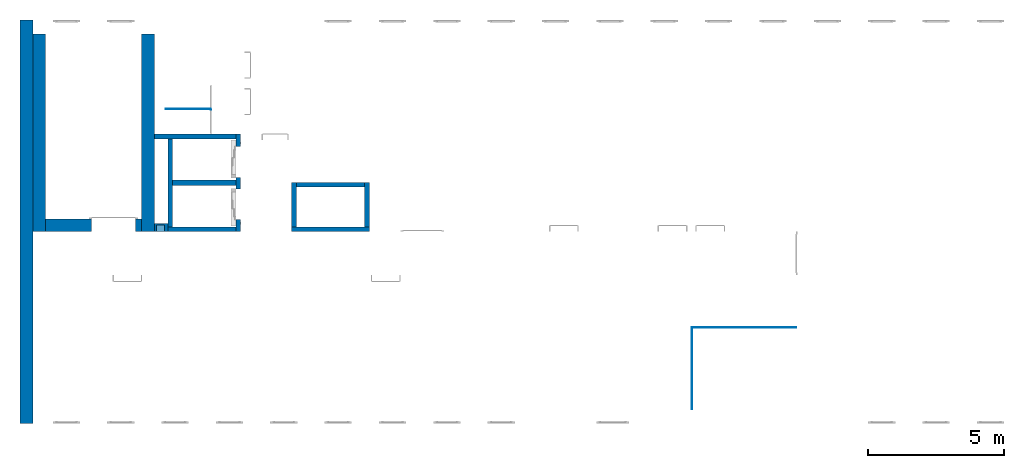
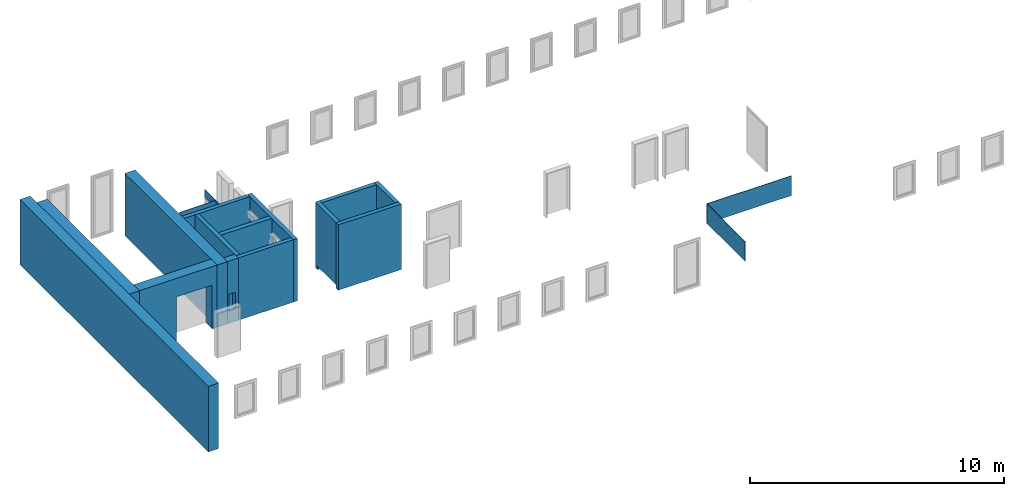
# One storey, part 1 of 5: 18 walls, 6 openings.
"""IFC4 building model written with IfcOpenShell, lengths in metres."""

from ifc_helpers import new_model, entity, si_unit, converted_unit, derived_unit, direction, frame, origin_with_axes, place, context, subcontext, project, spatial, polygons, material, type_object, element, save


model = new_model("IFC4")

# Units and contexts
model_context = context("Model", 3, precision=1e-05, world=origin_with_axes(), true_north=direction((0.0, 1.0)))
body_context = subcontext(model_context, "Body", "Model", "MODEL_VIEW")
ifc_project = project(units=[si_unit("LENGTHUNIT", "METRE"), si_unit("AREAUNIT", "SQUARE_METRE"), si_unit("VOLUMEUNIT", "CUBIC_METRE"), converted_unit("PLANEANGLEUNIT", "DEGREE", entity("IfcPlaneAngleMeasure", 0.0174532925199433), si_unit("PLANEANGLEUNIT", "RADIAN"), dimensions=[0, 0, 0, 0, 0, 0, 0]), converted_unit("TIMEUNIT", "Year", entity("IfcTimeMeasure", 31557600.0), si_unit("TIMEUNIT", "SECOND"), dimensions=[0, 0, 1, 0, 0, 0, 0]), si_unit("MASSUNIT", "GRAM", prefix="KILO"), si_unit("THERMODYNAMICTEMPERATUREUNIT", "DEGREE_CELSIUS"), si_unit("LUMINOUSINTENSITYUNIT", "LUMEN"), si_unit("ENERGYUNIT", "JOULE", prefix="MEGA"), derived_unit("THERMALCONDUCTANCEUNIT", [(si_unit("POWERUNIT", "WATT"), 1), (si_unit("LENGTHUNIT", "METRE"), -1), (si_unit("THERMODYNAMICTEMPERATUREUNIT", "KELVIN"), -1)]), derived_unit("SPECIFICHEATCAPACITYUNIT", [(si_unit("ENERGYUNIT", "JOULE"), 1), (si_unit("MASSUNIT", "GRAM", prefix="KILO"), -1), (si_unit("THERMODYNAMICTEMPERATUREUNIT", "KELVIN"), -1)]), derived_unit("MASSDENSITYUNIT", [(si_unit("MASSUNIT", "GRAM", prefix="KILO"), 1), (si_unit("VOLUMEUNIT", "CUBIC_METRE"), -1)])], contexts=[model_context])

# Site, building, storey
site_placement = place(None, origin_with_axes())
site = spatial("IfcSite", under=ifc_project, at=site_placement, CompositionType="ELEMENT")
building_placement = place(None, origin_with_axes())
building = spatial("IfcBuilding", under=site, at=building_placement, CompositionType="ELEMENT")
storey_placement = place(None, frame((0.0, 0.0, 4.5), z_axis=(0.0, 0.0, 1.0), x_axis=(1.0, 0.0, 0.0)))
storey = spatial("IfcBuildingStorey", under=building, at=storey_placement, Name="1 OG", CompositionType="ELEMENT", Elevation=4.5)

# Walls
ifc_material_1 = material(Name="Stahlbeton")
wall_type_1 = type_object("IfcWallType", Name="Stahlbeton 180", PredefinedType="NOTDEFINED")
wall_1_placement = place(None, frame((36.373, 7.05499994546756, 4.5), z_axis=(0.0, 0.0, 1.0), x_axis=(0.0, 1.0, 0.0)))
element("IfcWall", 1, at=wall_1_placement, inside=storey, type_object=wall_type_1, material=ifc_material_1, Name="Wand-001", PredefinedType="NOTDEFINED", context=body_context, shape_type="Tessellation", body=[
    polygons([(1.818, 0.18, 0.0), (1.818, 0.0, 0.0), (0.18, 0.0, 0.0), (0.18, 0.18, 0.0), (1.818, 0.18, 3.0), (1.818, 0.0, 3.0), (0.18, 0.0, 3.0), (0.18, 0.18, 3.0)], [[[1, 2, 3, 4]], [[2, 1, 5, 6]], [[2, 6, 7, 3]], [[8, 4, 3, 7]], [[5, 1, 4, 8]], [[6, 5, 8, 7]]], closed=True),
])
wall_2_placement = place(None, frame((28.958, 7.05499994546755, 4.5), z_axis=(0.0, 0.0, 1.0), x_axis=(1.0, 0.0, 0.0)))
element("IfcWall", 2, at=wall_2_placement, inside=storey, type_object=wall_type_1, material=ifc_material_1, Name="Wand-001", PredefinedType="NOTDEFINED", context=body_context, shape_type="Tessellation", body=[
    polygons([(2.5, 0.180000000000001, 0.0), (2.5, 0.0, 0.0), (0.0, 0.0, 0.0), (0.0, 0.18, 0.0), (2.5, 0.180000000000001, 3.0), (2.5, 0.0, 3.0), (0.0, 0.0, 3.0), (0.0, 0.180000000000001, 3.0)], [[[1, 2, 3, 4]], [[2, 1, 5, 6]], [[2, 6, 7, 3]], [[8, 4, 3, 7]], [[5, 1, 4, 8]], [[6, 5, 8, 7]]], closed=True),
])
wall_3_placement = place(None, frame((36.373, 8.87299994546756, 4.35), z_axis=(0.0, 0.0, 1.0), x_axis=(-1.0, 0.0, 0.0)))
element("IfcWall", 3, at=wall_3_placement, inside=storey, type_object=wall_type_1, material=ifc_material_1, Name="Wand-001", PredefinedType="NOTDEFINED", context=body_context, shape_type="Tessellation", body=[
    polygons([(2.688, 0.0, 3.15), (0.18, 0.0, 3.15), (0.18, 0.0, 0.15), (0.0, 0.0, 0.15), (0.0, 0.0, 0.0), (2.868, 0.0, 0.0), (2.868, 0.0, 0.15), (2.688, 0.0, 0.15), (2.688, 0.18, 3.15), (0.18, 0.18, 3.15), (0.18, 0.18, 0.15), (0.0, 0.18, 0.15), (0.0, 0.18, 0.0), (2.868, 0.18, 0.0), (2.868, 0.18, 0.15), (2.688, 0.18, 0.15)], [[[1, 2, 3, 4, 5, 6, 7, 8]], [[9, 10, 2, 1]], [[11, 3, 2, 10]], [[11, 12, 4, 3]], [[5, 4, 12, 13]], [[5, 13, 14, 6]], [[14, 15, 7, 6]], [[16, 8, 7, 15]], [[16, 9, 1, 8]], [[12, 11, 10, 9, 16, 15, 14, 13]]], closed=True),
])
wall_4_placement = place(None, frame((29.138, 7.05499994546755, 4.5), z_axis=(0.0, 0.0, 1.0), x_axis=(0.0, 1.0, 0.0)))
element("IfcWall", 4, at=wall_4_placement, inside=storey, type_object=wall_type_1, material=ifc_material_1, Name="Wand-003", PredefinedType="NOTDEFINED", context=body_context, shape_type="Tessellation", body=[
    polygons([(3.42, 0.18, 0.0), (3.42, 0.0, 0.0), (0.18, 0.0, 0.0), (0.18, 0.18, 0.0), (3.42, 0.18, 3.0), (3.42, 0.0, 3.0), (0.18, 0.0, 3.0), (0.18, 0.18, 3.0)], [[[1, 2, 3, 4]], [[2, 1, 5, 6]], [[2, 6, 7, 3]], [[8, 4, 3, 7]], [[5, 1, 4, 8]], [[6, 5, 8, 7]]], closed=True),
])
wall_5_placement = place(None, frame((31.638, 10.6549999454676, 4.5), z_axis=(0.0, 0.0, 1.0), x_axis=(-1.0, 0.0, 0.0)))
element("IfcWall", 5, at=wall_5_placement, inside=storey, type_object=wall_type_1, material=ifc_material_1, Name="Wand-003", PredefinedType="NOTDEFINED", context=body_context, shape_type="Tessellation", body=[
    polygons([(3.18, 0.18, 0.0), (3.18, 0.0, 0.0), (0.18, 0.0, 0.0), (0.18, 0.18, 0.0), (3.18, 0.18, 3.0), (3.18, 0.0, 3.0), (0.18, 0.0, 3.0), (0.18, 0.18, 3.0)], [[[1, 2, 3, 4]], [[2, 1, 5, 6]], [[2, 6, 7, 3]], [[8, 4, 3, 7]], [[5, 1, 4, 8]], [[6, 5, 8, 7]]], closed=True),
])
wall_6_placement = place(None, frame((33.505, 7.05499994546756, 4.35), z_axis=(0.0, 0.0, 1.0), x_axis=(1.0, 0.0, 0.0)))
element("IfcWall", 6, at=wall_6_placement, inside=storey, type_object=wall_type_1, material=ifc_material_1, Name="Wand-001", PredefinedType="NOTDEFINED", context=body_context, shape_type="Tessellation", body=[
    polygons([(2.868, 0.0, 3.15), (2.868, 0.0, 0.15), (2.868, 0.18, 0.15), (2.868, 0.180000000000001, 3.15), (0.0, 0.0, 0.0), (2.868, 0.0, 0.0), (0.0, 0.0, 3.15), (0.0, 0.0, 0.15), (2.868, 0.18, 0.0), (0.0, 0.18, 0.0), (0.0, 0.18, 0.15), (0.0, 0.180000000000001, 3.15)], [[[1, 2, 3, 4]], [[5, 6, 2, 1, 7, 8]], [[6, 9, 3, 2]], [[4, 3, 9, 10, 11, 12]], [[7, 1, 4, 12]], [[10, 9, 6, 5]], [[12, 11, 8, 7]], [[5, 8, 11, 10]]], closed=True),
])
wall_7_placement = place(None, frame((33.505, 7.05499994546756, 4.5), z_axis=(0.0, 0.0, 1.0), x_axis=(0.0, 1.0, 0.0)))
element("IfcWall", 7, at=wall_7_placement, inside=storey, type_object=wall_type_1, material=ifc_material_1, Name="Wand-001", PredefinedType="NOTDEFINED", context=body_context, shape_type="Tessellation", body=[
    polygons([(1.818, -0.18, 3.0), (1.818, 0.0, 3.0), (0.18, 0.0, 3.0), (0.18, -0.18, 3.0), (1.818, -0.18, 0.0), (1.818, 0.0, 0.0), (0.18, 0.0, 0.0), (0.18, -0.18, 0.0)], [[[1, 2, 3, 4]], [[2, 1, 5, 6]], [[2, 6, 7, 3]], [[8, 4, 3, 7]], [[5, 1, 4, 8]], [[6, 5, 8, 7]]], closed=True),
])

# Wall, openings
wall_8_placement = place(None, frame((31.638, 7.05499994546755, 4.5), z_axis=(0.0, 0.0, 1.0), x_axis=(0.0, 1.0, 0.0)))
wall_8 = element("IfcWall", 8, at=wall_8_placement, inside=storey, type_object=wall_type_1, material=ifc_material_1, Name="Wand-002", PredefinedType="NOTDEFINED", context=body_context, shape_type="Tessellation", body=[
    polygons([(2.0, 0.0, 0.0), (2.0, 0.0, 2.25), (3.13, 0.0, 2.25), (3.13, 0.0, 0.0), (3.6, 0.0, 0.0), (3.6, 0.0, 3.0), (0.0, 0.0, 3.0), (0.0, 0.0, 0.0), (0.450000000000002, 0.0, 0.0), (0.450000000000002, 0.0, 2.25), (1.58, 0.0, 2.25), (1.58, 0.0, 0.0), (2.0, 0.179999999999996, 0.0), (2.0, 0.179999999999996, 2.25), (3.13, 0.179999999999996, 2.25), (3.13, 0.179999999999996, 0.0), (3.6, 0.179999999999996, 0.0), (3.6, 0.179999999999996, 3.0), (0.0, 0.18, 3.0), (0.0, 0.18, 0.0), (0.450000000000002, 0.18, 0.0), (0.450000000000002, 0.18, 2.25), (1.58, 0.18, 2.25), (1.58, 0.18, 0.0)], [[[1, 2, 3, 4, 5, 6, 7, 8, 9, 10, 11, 12]], [[2, 1, 13, 14]], [[3, 2, 14, 15]], [[4, 3, 15, 16]], [[4, 16, 17, 5]], [[18, 6, 5, 17]], [[19, 7, 6, 18]], [[8, 7, 19, 20]], [[9, 8, 20, 21]], [[9, 21, 22, 10]], [[10, 22, 23, 11]], [[11, 23, 24, 12]], [[13, 1, 12, 24]], [[14, 13, 24, 23, 22, 21, 20, 19, 18, 17, 16, 15]]], closed=True),
])
opening_1_placement = place(None, frame((31.638, 8.06999994546756, 4.5), z_axis=(0.0, 0.0, 1.0), x_axis=(0.0, 1.0, 0.0)))
element("IfcOpeningElement", 9, at=opening_1_placement, cuts=wall_8, context=body_context, identifier="Reference", shape_type="Tessellation", body=[
    polygons([(-0.565, -0.00100000000000122, 2.25), (-0.565, -0.00100000000000122, 0.0), (0.565, -0.00100000000000122, 0.0), (0.565, -0.00100000000000122, 2.25), (-0.565, 0.181000000000004, 2.25), (-0.565, 0.181000000000004, 0.0), (0.565000000000001, 0.181000000000004, 0.0), (0.565000000000001, 0.181000000000004, 2.25)], [[[1, 2, 3, 4]], [[5, 6, 2, 1]], [[6, 7, 3, 2]], [[7, 8, 4, 3]], [[8, 5, 1, 4]], [[7, 6, 5, 8]]], closed=True),
])
opening_2_placement = place(wall_8_placement, frame((2.565, 0.0, 0.0), z_axis=(0.0, 0.0, 1.0), x_axis=(1.0, 0.0, 0.0)))
element("IfcOpeningElement", 10, at=opening_2_placement, cuts=wall_8, context=body_context, identifier="Reference", shape_type="Tessellation", body=[
    polygons([(-0.565, -0.00100000000000478, 2.25), (-0.565, -0.00100000000000478, 0.0), (0.565, -0.00100000000000478, 0.0), (0.565, -0.00100000000000478, 2.25), (-0.564999999999998, 0.181000000000001, 2.25), (-0.564999999999998, 0.181000000000001, 0.0), (0.565000000000001, 0.181000000000001, 0.0), (0.565000000000001, 0.181000000000001, 2.25)], [[[1, 2, 3, 4]], [[5, 6, 2, 1]], [[6, 7, 3, 2]], [[7, 8, 4, 3]], [[8, 5, 1, 4]], [[7, 6, 5, 8]]], closed=True),
])

# Walls
wall_type_2 = type_object("IfcWallType", Name="Stahlbeton 470", PredefinedType="NOTDEFINED")
wall_9_placement = place(None, frame((27.988, 14.3259998818788, 4.5), z_axis=(0.0, 0.0, 1.0), x_axis=(0.0, -1.0, 0.0)))
element("IfcWall", 11, at=wall_9_placement, inside=storey, type_object=wall_type_2, material=ifc_material_1, Name="Wand-001", PredefinedType="NOTDEFINED", context=body_context, shape_type="Tessellation", body=[
    polygons([(7.27099993641123, 0.469999999999999, 0.0), (7.27099993641123, 0.0, 0.0), (0.0, 0.0, 0.0), (0.0, 0.469999999999999, 0.0), (7.27099993641123, 0.469999999999999, 3.0), (7.27099993641123, 0.0, 3.0), (0.0, 0.0, 3.0), (0.0, 0.469999999999999, 3.0)], [[[1, 2, 3, 4]], [[2, 1, 5, 6]], [[2, 6, 7, 3]], [[8, 4, 3, 7]], [[5, 1, 4, 8]], [[6, 5, 8, 7]]], closed=True),
])
wall_10_placement = place(None, frame((23.988, 14.8459998818788, 4.35), z_axis=(0.0, 0.0, 1.0), x_axis=(0.0, -1.0, 0.0)))
element("IfcWall", 12, at=wall_10_placement, inside=storey, type_object=wall_type_2, material=ifc_material_1, Name="Wand-001", PredefinedType="NOTDEFINED", context=body_context, shape_type="Tessellation", body=[
    polygons([(0.0, 0.0, 0.0), (0.0, 0.0, 3.15), (14.8459998818788, 0.0, 3.15), (14.8459998818788, 0.0, 0.0), (0.362999951604566, 0.0, 3.0), (0.362999951604566, 0.0, 2.63), (7.79099993641123, 0.0, 2.63), (14.4829998291425, 0.0, 2.63), (14.4829998291425, 0.0, 3.0), (7.79099993641123, 0.0, 3.0), (0.0, -0.469999999999999, 0.0), (0.0, -0.469999999999999, 3.15), (14.8459998818788, -0.469999999999999, 3.15), (14.8459998818788, -0.469999999999999, 0.0), (0.362999951604566, -0.100000000000008, 2.63), (0.362999951604566, -0.100000000000008, 3.0), (14.4829998289544, -0.100000000000008, 2.63), (14.4829998289544, -0.100000000000008, 3.0)], [[[1, 2, 3, 4], [5, 6, 7, 8, 9, 10]], [[1, 11, 12, 2]], [[2, 12, 13, 3]], [[4, 3, 13, 14]], [[11, 1, 4, 14]], [[15, 6, 5, 16]], [[8, 7, 6, 15, 17]], [[18, 9, 8, 17]], [[18, 16, 5, 10, 9]], [[12, 11, 14, 13]], [[17, 15, 16, 18]]], closed=True),
])
wall_11_placement = place(None, frame((24.458, 14.3318657372406, 4.5), z_axis=(0.0, 0.0, 1.0), x_axis=(0.0, -1.0, 0.0)))
element("IfcWall", 13, at=wall_11_placement, inside=storey, type_object=wall_type_2, material=ifc_material_1, Name="Wand-001", PredefinedType="NOTDEFINED", context=body_context, shape_type="Tessellation", body=[
    polygons([(7.27686579177299, -0.470000000000002, 3.0), (7.27686579177299, 0.0, 3.0), (0.0, 0.0, 3.0), (0.0, -0.469999999999999, 3.0), (7.27686579177299, -0.470000000000002, 0.0), (7.27686579177299, 0.0, 0.0), (0.0, 0.0, 0.0), (0.0, -0.469999999999999, 0.0)], [[[1, 2, 3, 4]], [[2, 1, 5, 6]], [[2, 6, 7, 3]], [[8, 4, 3, 7]], [[5, 1, 4, 8]], [[6, 5, 8, 7]]], closed=True),
])

# Wall, opening
wall_12_placement = place(None, frame((24.458, 7.52499994546755, 4.5), z_axis=(0.0, 0.0, 1.0), x_axis=(1.0, 0.0, 0.0)))
wall_12 = element("IfcWall", 14, at=wall_12_placement, inside=storey, type_object=wall_type_2, material=ifc_material_1, Name="Wand-001", PredefinedType="NOTDEFINED", context=body_context, shape_type="Tessellation", body=[
    polygons([(1.69000000000001, 0.0, 2.11), (1.69000000000001, 0.0, 0.0), (0.0, 0.0, 0.0), (0.0, 0.0, 3.0), (3.53, 0.0, 3.0), (3.53, 0.0, 0.0), (3.31, 0.0, 0.0), (3.31, 0.0, 2.11), (1.69000000000001, -0.47, 2.11), (1.69000000000001, -0.47, 0.0), (0.0, -0.47, 0.0), (0.0, -0.47, 3.0), (3.53, -0.47, 3.0), (3.53, -0.47, 0.0), (3.31, -0.47, 0.0), (3.31, -0.47, 2.11)], [[[1, 2, 3, 4, 5, 6, 7, 8]], [[2, 1, 9, 10]], [[2, 10, 11, 3]], [[12, 4, 3, 11]], [[5, 4, 12, 13]], [[13, 14, 6, 5]], [[15, 7, 6, 14]], [[8, 7, 15, 16]], [[1, 8, 16, 9]], [[16, 15, 14, 13, 12, 11, 10, 9]]], closed=True),
])
opening_3_placement = place(wall_12_placement, frame((2.5, 0.0, 0.0), z_axis=(0.0, 0.0, 1.0), x_axis=(1.0, 0.0, 0.0)))
element("IfcOpeningElement", 15, at=opening_3_placement, cuts=wall_12, context=body_context, identifier="Reference", shape_type="Tessellation", body=[
    polygons([(-0.809999999999999, -0.471, 2.11), (-0.809999999999999, -0.471, 0.0), (0.809999999999999, -0.471, 0.0), (0.809999999999999, -0.471, 2.11), (-0.809999999999999, 0.00100000000000033, 2.11), (-0.809999999999999, 0.00100000000000033, 0.0), (0.809999999999999, 0.00100000000000033, 0.0), (0.809999999999999, 0.00100000000000033, 2.11)], [[[1, 2, 3, 4]], [[5, 6, 2, 1]], [[6, 7, 3, 2]], [[7, 8, 4, 3]], [[8, 5, 1, 4]], [[7, 6, 5, 8]]], closed=True),
])

# Wall
wall_type_3 = type_object("IfcWallType", Name="Stahlbeton 200", PredefinedType="NOTDEFINED")
wall_13_placement = place(None, frame((29.138, 8.85499994546755, 4.5), z_axis=(0.0, 0.0, 1.0), x_axis=(1.0, 0.0, 0.0)))
element("IfcWall", 16, at=wall_13_placement, inside=storey, type_object=wall_type_3, material=ifc_material_1, Name="Wand-001", PredefinedType="NOTDEFINED", context=body_context, shape_type="Tessellation", body=[
    polygons([(2.32, 0.0999999999999996, 0.0), (2.32, -0.0999999999999996, 0.0), (0.0, -0.0999999999999996, 0.0), (0.0, 0.0999999999999996, 0.0), (2.32, 0.0999999999999996, 3.0), (2.32, -0.0999999999999996, 3.0), (0.0, -0.0999999999999996, 3.0), (0.0, 0.0999999999999996, 3.0)], [[[1, 2, 3, 4]], [[2, 1, 5, 6]], [[2, 6, 7, 3]], [[8, 4, 3, 7]], [[5, 1, 4, 8]], [[6, 5, 8, 7]]], closed=True),
])

# Wall, opening
wall_type_4 = type_object("IfcWallType", Name="Stahlbeton 300", PredefinedType="NOTDEFINED")
wall_14_placement = place(None, frame((28.458, 7.05499994546755, 4.5), z_axis=(0.0, 0.0, 1.0), x_axis=(1.0, 0.0, 0.0)))
wall_14 = element("IfcWall", 17, at=wall_14_placement, inside=storey, type_object=wall_type_4, material=ifc_material_1, Name="Wand-001", PredefinedType="NOTDEFINED", context=body_context, shape_type="Tessellation", body=[
    polygons([(0.0, 0.0, 3.0), (0.0, 0.0, 0.0), (0.5, 0.0, 0.0), (0.5, 0.0, 3.0), (0.375425898351669, 0.0, 0.6), (0.0754258983516713, 0.0, 0.6), (0.0754258983516713, 0.0, 1.4), (0.375425898351669, 0.0, 1.4), (0.0, 0.3, 3.0), (0.0, 0.3, 0.0), (0.5, 0.3, 0.0), (0.5, 0.3, 3.0), (0.0754258983516713, 0.25, 0.6), (0.375425898351669, 0.25, 0.6), (0.0754258983516713, 0.25, 1.4), (0.375425898351669, 0.25, 1.4)], [[[1, 2, 3, 4], [5, 6, 7, 8]], [[1, 9, 10, 2]], [[2, 10, 11, 3]], [[4, 3, 11, 12]], [[9, 1, 4, 12]], [[13, 6, 5, 14]], [[15, 7, 6, 13]], [[16, 8, 7, 15]], [[14, 5, 8, 16]], [[10, 9, 12, 11]], [[13, 14, 16, 15]]], closed=True),
])
opening_4_placement = place(None, origin_with_axes())
element("IfcOpeningElement", 18, at=opening_4_placement, cuts=wall_14, PredefinedType="NOTDEFINED", context=body_context, identifier="Reference", shape_type="Tessellation", body=[
    polygons([(28.5334258983517, 7.30499994546755, 5.1), (28.8334258983517, 7.30499994546755, 5.1), (28.8334258983517, 6.75499994546755, 5.1), (28.5334258983517, 6.75499994546755, 5.1), (28.5334258983517, 7.30499994546755, 5.9), (28.8334258983517, 7.30499994546755, 5.9), (28.8334258983517, 6.75499994546755, 5.9), (28.5334258983517, 6.75499994546755, 5.9)], [[[1, 2, 3, 4]], [[1, 5, 6, 2]], [[2, 6, 7, 3]], [[4, 3, 7, 8]], [[5, 1, 4, 8]], [[6, 5, 8, 7]]], closed=True),
])

# Space
space_placement = place(None, frame((28.883, 12.4404999136732, 4.5), z_axis=(0.0, 0.0, 1.0), x_axis=(0.0, -1.0, 0.0)))
space = spatial("IfcSpace", under=storey, at=space_placement, CompositionType="ELEMENT", PredefinedType="NOTDEFINED")

# Wall, openings
ifc_material_2 = material(Name="Kunststoff")
wall_type_5 = type_object("IfcWallType", Name="Kunststoff 20", PredefinedType="NOTDEFINED")
wall_15_placement = place(None, frame((30.553, 10.6549999454676, 4.35), z_axis=(0.0, 0.0, 1.0), x_axis=(0.0, 1.0, 0.0)))
wall_15 = element("IfcWall", 19, at=wall_15_placement, inside=space, type_object=wall_type_5, material=ifc_material_2, Name="Wand-003", PredefinedType="NOTDEFINED", context=body_context, shape_type="Tessellation", body=[
    polygons([(0.895499968205613, 0.0, 0.15), (0.895499968205613, 0.0, 2.245), (1.78549996820561, 0.0, 2.245), (1.78549996820561, 0.0, 2.63), (0.0, 0.0, 2.63), (0.0, 0.0, 2.245), (0.890000000000001, 0.0, 2.245), (0.890000000000001, 0.0, 0.15), (0.895499968205613, 0.0199999999999996, 0.15), (0.895499968205613, 0.0199999999999996, 2.245), (1.78549996820561, 0.0199999999999996, 2.245), (1.78549996820561, 0.0199999999999996, 2.63), (0.0, 0.0199999999999996, 2.63), (0.0, 0.0199999999999996, 2.245), (0.890000000000001, 0.0199999999999996, 2.245), (0.890000000000001, 0.0199999999999996, 0.15)], [[[1, 2, 3, 4, 5, 6, 7, 8]], [[2, 1, 9, 10]], [[11, 3, 2, 10]], [[3, 11, 12, 4]], [[13, 5, 4, 12]], [[6, 5, 13, 14]], [[6, 14, 15, 7]], [[7, 15, 16, 8]], [[9, 1, 8, 16]], [[10, 9, 16, 15, 14, 13, 12, 11]]], closed=True),
])
opening_5_placement = place(None, frame((30.553, 11.9954999136732, 4.55), z_axis=(0.0, 0.0, 1.0), x_axis=(0.0, 1.0, 0.0)))
element("IfcOpeningElement", 20, at=opening_5_placement, cuts=wall_15, context=body_context, identifier="Reference", shape_type="Tessellation", body=[
    polygons([(0.445, 0.0210000000000008, 2.045), (0.445, 0.0210000000000008, -0.0499999999999998), (-0.445, 0.0210000000000008, -0.0499999999999998), (-0.445, 0.0210000000000008, 2.045), (0.445, -0.00100000000000122, 2.045), (0.445, -0.00100000000000122, -0.0499999999999998), (-0.445, -0.00100000000000122, -0.0499999999999998), (-0.445, -0.00100000000000122, 2.045)], [[[1, 2, 3, 4]], [[5, 6, 2, 1]], [[6, 7, 3, 2]], [[7, 8, 4, 3]], [[8, 5, 1, 4]], [[7, 6, 5, 8]]], closed=True),
])
opening_6_placement = place(wall_15_placement, frame((0.445, 0.0, 0.2), z_axis=(0.0, 0.0, 1.0), x_axis=(1.0, 0.0, 0.0)))
element("IfcOpeningElement", 21, at=opening_6_placement, cuts=wall_15, context=body_context, identifier="Reference", shape_type="Tessellation", body=[
    polygons([(0.445, 0.0210000000000008, 2.045), (0.445, 0.0210000000000008, -0.0499999999999998), (-0.445, 0.0210000000000008, -0.0499999999999998), (-0.445, 0.0210000000000008, 2.045), (0.445, -0.00100000000000122, 2.045), (0.445, -0.00100000000000122, -0.0499999999999998), (-0.445, -0.00100000000000122, -0.0499999999999998), (-0.445, -0.00100000000000122, 2.045)], [[[1, 2, 3, 4]], [[5, 6, 2, 1]], [[6, 7, 3, 2]], [[7, 8, 4, 3]], [[8, 5, 1, 4]], [[7, 6, 5, 8]]], closed=True),
])

# Walls
wall_16_placement = place(None, frame((30.553, 11.5727499295704, 4.35), z_axis=(0.0, 0.0, 1.0), x_axis=(-1.0, 0.0, 0.0)))
element("IfcWall", 22, at=wall_16_placement, inside=space, type_object=wall_type_5, material=ifc_material_2, Name="Wand-003", PredefinedType="NOTDEFINED", context=body_context, shape_type="Tessellation", body=[
    polygons([(0.0199999999999996, -0.00999999999999979, 2.63), (0.0199999999999996, 0.00999999999999979, 2.63), (0.0199999999999996, 0.00999999999999979, 0.15), (0.0199999999999996, -0.00999999999999979, 0.15), (1.67, -0.00999999999999979, 2.63), (1.67, 0.00999999999999979, 2.63), (1.67, 0.00999999999999979, 0.15), (1.67, -0.00999999999999979, 0.15)], [[[1, 2, 3, 4]], [[2, 1, 5, 6]], [[2, 6, 7, 3]], [[3, 7, 8, 4]], [[5, 1, 4, 8]], [[6, 5, 8, 7]]], closed=True),
])
ifc_material_3 = material()
wall_type_6 = type_object("IfcWallType", Name="20", PredefinedType="NOTDEFINED")
wall_17_placement = place(None, frame((52.078, 3.52, 4.55), z_axis=(0.0, 0.0, 1.0), x_axis=(-1.0, 0.0, 0.0)))
element("IfcWall", 23, at=wall_17_placement, inside=storey, type_object=wall_type_6, material=ifc_material_3, Name="Wand-003", PredefinedType="NOTDEFINED", context=body_context, shape_type="Tessellation", body=[
    polygons([(3.84, 0.0, 0.95), (0.0, 0.0, 0.95), (0.0, -0.02, 0.95), (3.84, -0.0199999999999996, 0.95), (3.84, 0.0, 0.0), (0.0, 0.0, 0.0), (0.0, -0.02, 0.0), (3.84, -0.02, 0.0)], [[[1, 2, 3, 4]], [[5, 6, 2, 1]], [[3, 2, 6, 7]], [[4, 3, 7, 8]], [[4, 8, 5, 1]], [[8, 7, 6, 5]]], closed=True),
])
wall_18_placement = place(None, frame((48.258, 3.52, 4.55), z_axis=(0.0, 0.0, 1.0), x_axis=(0.0, -1.0, 0.0)))
element("IfcWall", 24, at=wall_18_placement, inside=storey, type_object=wall_type_6, material=ifc_material_3, Name="Wand-003", PredefinedType="NOTDEFINED", context=body_context, shape_type="Tessellation", body=[
    polygons([(3.0, -0.0200000000000031, 0.95), (3.0, 0.0, 0.95), (0.0, 0.0, 0.95), (0.0, -0.0200000000000031, 0.95), (3.0, -0.0200000000000031, 0.0), (3.0, 0.0, 0.0), (0.0, 0.0, 0.0), (0.0, -0.0200000000000031, 0.0)], [[[1, 2, 3, 4]], [[1, 5, 6, 2]], [[2, 6, 7, 3]], [[4, 3, 7, 8]], [[5, 1, 4, 8]], [[6, 5, 8, 7]]], closed=True),
])

save(model, "model.ifc")
